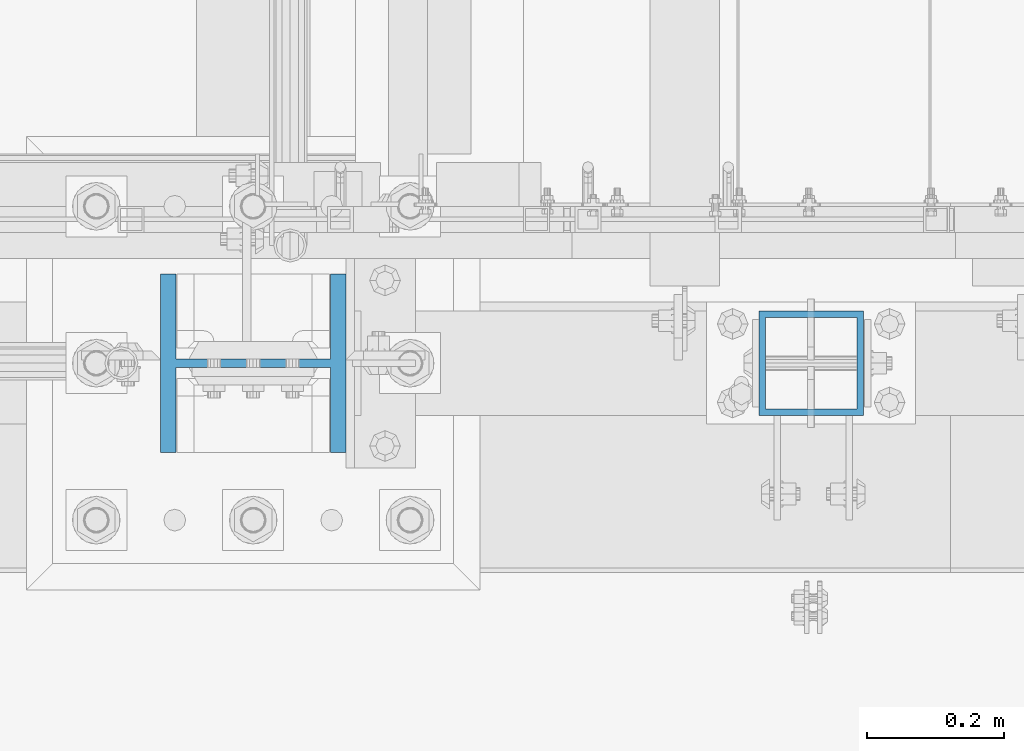
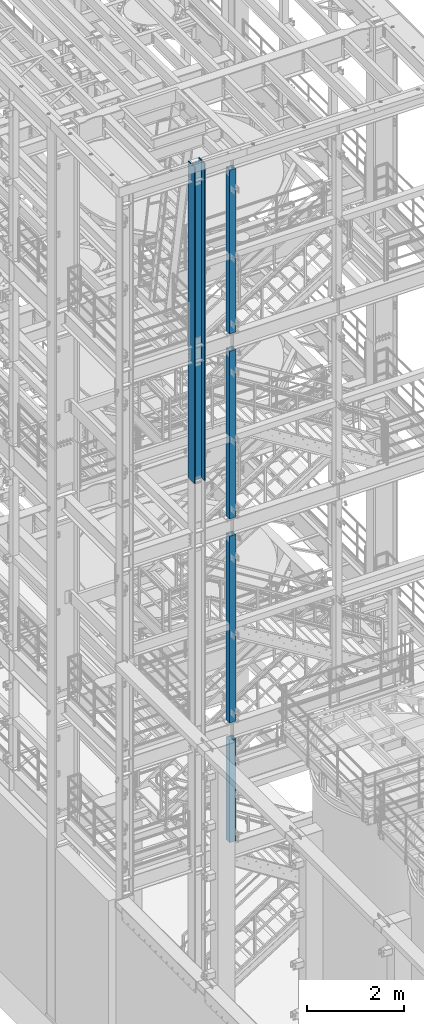
# One storey, part 568 of 1876: 5 columns, 5 elements without a shape of their own.
"""IFC2X3 building model written with IfcOpenShell, lengths in millimetres."""

from ifc_helpers import new_model, si_unit, frame, origin_with_axes, place, context, subcontext, project, spatial, faceted_brep, material, type_object, element, aggregate, save


model = new_model("IFC2X3")

# Units and contexts
model_context = context("Model", 3, precision=1e-05, world=origin_with_axes())
body_context = subcontext(model_context, "Body", "Model", "MODEL_VIEW")
ifc_project = project(units=[si_unit("LENGTHUNIT", "METRE", prefix="MILLI"), si_unit("AREAUNIT", "SQUARE_METRE"), si_unit("VOLUMEUNIT", "CUBIC_METRE"), si_unit("MASSUNIT", "GRAM", prefix="KILO"), si_unit("TIMEUNIT", "SECOND"), si_unit("PLANEANGLEUNIT", "RADIAN"), si_unit("SOLIDANGLEUNIT", "STERADIAN"), si_unit("THERMODYNAMICTEMPERATUREUNIT", "DEGREE_CELSIUS"), si_unit("LUMINOUSINTENSITYUNIT", "LUMEN")], contexts=[model_context])

# Site, building, storey
site_placement = place(None, origin_with_axes())
site = spatial("IfcSite", under=ifc_project, at=site_placement, CompositionType="ELEMENT")
building_placement = place(site_placement, origin_with_axes())
building = spatial("IfcBuilding", under=site, at=building_placement, Name="Undefined", CompositionType="ELEMENT")
storey_placement = place(building_placement, origin_with_axes())
storey = spatial("IfcBuildingStorey", under=building, at=storey_placement, Name="Undefined", CompositionType="ELEMENT", Elevation=0.0)

# Assembly, column
assembly_1_placement = place(storey_placement, origin_with_axes())
assembly_1 = element("IfcElementAssembly", 1, at=assembly_1_placement, inside=storey, Name="FRAME", AssemblyPlace="NOTDEFINED", PredefinedType="RIGID_FRAME")
ifc_material_1 = material()
column_type_1 = type_object("IfcColumnType", Name="HSS6X6X3/8", PredefinedType="NOTDEFINED")
column_1_placement = place(assembly_1_placement, frame((2540.0, -7112.0, 17983.2), z_axis=(-1.0, 0.0, 0.0), x_axis=(0.0, 0.0, 1.0)))
column_1 = element("IfcColumn", 2, at=column_1_placement, type_object=column_type_1, material=ifc_material_1, Name="COLUMN", ObjectType="HSS6X6X3/8", context=body_context, shape_type="Brep", body=[
    faceted_brep([(12.7000000000016, 66.6750000000002, -66.6750000000002), (12.7000000000016, -66.6750000000002, -66.6750000000002), (4149.72500000001, -66.6750000000002, -66.6750000000002), (4149.72500000001, 66.6750000000002, -66.6750000000002), (12.7000000000016, -66.6750000000002, 66.6750000000002), (4149.72500000001, -66.6750000000002, 66.6750000000002), (12.7000000000016, 66.6750000000002, 66.6750000000002), (4149.72500000001, 66.6750000000002, 66.6750000000002), (12.7000000000016, 76.1999999999998, -76.1999999999998), (12.7000000000016, 76.1999999999998, 76.1999999999998), (4149.72500000001, 76.1999999999998, 76.1999999999998), (4149.72500000001, 76.1999999999998, -76.1999999999998), (12.7000000000016, -76.1999999999998, 76.1999999999998), (4149.72500000001, -76.1999999999998, 76.1999999999998), (12.7000000000016, -76.1999999999998, -76.1999999999998), (4149.72500000001, -76.1999999999998, -76.1999999999998)], [[[0, 1, 2, 3]], [[1, 4, 5, 2]], [[4, 6, 7, 5]], [[6, 0, 3, 7]], [[8, 9, 10, 11]], [[9, 12, 13, 10]], [[12, 14, 15, 13]], [[14, 8, 11, 15]], [[13, 15, 11, 10], [5, 7, 3, 2]], [[14, 12, 9, 8], [6, 4, 1, 0]]]),
])
aggregate(assembly_1, [column_1])

assembly_2_placement = place(storey_placement, origin_with_axes())
assembly_2 = element("IfcElementAssembly", 3, at=assembly_2_placement, inside=storey, Name="FRAME", AssemblyPlace="NOTDEFINED", PredefinedType="RIGID_FRAME")
column_2_placement = place(assembly_2_placement, frame((2540.0, -7112.0, 13309.6), z_axis=(-1.0, 0.0, 0.0), x_axis=(0.0, 0.0, 1.0)))
column_2 = element("IfcColumn", 4, at=column_2_placement, type_object=column_type_1, material=ifc_material_1, Name="COLUMN", ObjectType="HSS6X6X3/8", context=body_context, shape_type="Brep", body=[
    faceted_brep([(12.7000000000016, 66.6750000000002, -66.6750000000002), (12.7000000000016, -66.6750000000002, -66.6750000000002), (4251.325, -66.6750000000002, -66.6750000000002), (4251.325, 66.6750000000002, -66.6750000000002), (12.7000000000016, -66.6750000000002, 66.6750000000002), (4251.325, -66.6750000000002, 66.6750000000002), (12.7000000000016, 66.6750000000002, 66.6750000000002), (4251.325, 66.6750000000002, 66.6750000000002), (12.7000000000016, 76.1999999999998, -76.1999999999998), (12.7000000000016, 76.1999999999998, 76.1999999999998), (4251.325, 76.1999999999998, 76.1999999999998), (4251.325, 76.1999999999998, -76.1999999999998), (12.7000000000016, -76.1999999999998, 76.1999999999998), (4251.325, -76.1999999999998, 76.1999999999998), (12.7000000000016, -76.1999999999998, -76.1999999999998), (4251.325, -76.1999999999998, -76.1999999999998)], [[[0, 1, 2, 3]], [[1, 4, 5, 2]], [[4, 6, 7, 5]], [[6, 0, 3, 7]], [[8, 9, 10, 11]], [[9, 12, 13, 10]], [[12, 14, 15, 13]], [[14, 8, 11, 15]], [[13, 15, 11, 10], [5, 7, 3, 2]], [[14, 12, 9, 8], [6, 4, 1, 0]]]),
])
aggregate(assembly_2, [column_2])

assembly_3_placement = place(storey_placement, origin_with_axes())
assembly_3 = element("IfcElementAssembly", 5, at=assembly_3_placement, inside=storey, Name="FRAME", AssemblyPlace="NOTDEFINED", PredefinedType="RIGID_FRAME")
column_3_placement = place(assembly_3_placement, frame((2540.0, -7112.0, 8153.4), z_axis=(-1.0, 0.0, 0.0), x_axis=(0.0, 0.0, 1.0)))
column_3 = element("IfcColumn", 6, at=column_3_placement, type_object=column_type_1, material=ifc_material_1, Name="COLUMN", ObjectType="HSS6X6X3/8", context=body_context, shape_type="Brep", body=[
    faceted_brep([(12.7000000000016, 66.6750000000002, -66.6750000000002), (12.7000000000016, -66.6750000000002, -66.6750000000002), (4733.925, -66.6750000000002, -66.6750000000002), (4733.925, 66.6750000000002, -66.6750000000002), (12.7000000000016, -66.6750000000002, 66.6750000000002), (4733.925, -66.6750000000002, 66.6750000000002), (12.7000000000016, 66.6750000000002, 66.6750000000002), (4733.925, 66.6750000000002, 66.6750000000002), (12.7000000000016, 76.1999999999998, -76.1999999999998), (12.7000000000016, 76.1999999999998, 76.1999999999998), (4733.925, 76.1999999999998, 76.1999999999998), (4733.925, 76.1999999999998, -76.1999999999998), (12.7000000000016, -76.1999999999998, 76.1999999999998), (4733.925, -76.1999999999998, 76.1999999999998), (12.7000000000016, -76.1999999999998, -76.1999999999998), (4733.925, -76.1999999999998, -76.1999999999998)], [[[0, 1, 2, 3]], [[1, 4, 5, 2]], [[4, 6, 7, 5]], [[6, 0, 3, 7]], [[8, 9, 10, 11]], [[9, 12, 13, 10]], [[12, 14, 15, 13]], [[14, 8, 11, 15]], [[13, 15, 11, 10], [5, 7, 3, 2]], [[14, 12, 9, 8], [6, 4, 1, 0]]]),
])
aggregate(assembly_3, [column_3])

assembly_4_placement = place(storey_placement, origin_with_axes())
assembly_4 = element("IfcElementAssembly", 7, at=assembly_4_placement, inside=storey, Name="FRAME", AssemblyPlace="NOTDEFINED", PredefinedType="RIGID_FRAME")
column_4_placement = place(assembly_4_placement, frame((2540.0, -7112.0, 5130.8), z_axis=(-1.0, 0.0, 0.0), x_axis=(0.0, 0.0, 1.0)))
column_4 = element("IfcColumn", 8, at=column_4_placement, type_object=column_type_1, material=ifc_material_1, Name="COLUMN", ObjectType="HSS6X6X3/8", context=body_context, shape_type="Brep", body=[
    faceted_brep([(12.7000000000016, 66.6750000000002, -66.6750000000002), (12.7000000000016, -66.6750000000002, -66.6750000000002), (2600.325, -66.6750000000002, -66.6750000000002), (2600.325, 66.6750000000002, -66.6750000000002), (12.7000000000016, -66.6750000000002, 66.6750000000002), (2600.325, -66.6750000000002, 66.6750000000002), (12.7000000000016, 66.6750000000002, 66.6750000000002), (2600.325, 66.6750000000002, 66.6750000000002), (12.7000000000016, 76.1999999999998, -76.1999999999998), (12.7000000000016, 76.1999999999998, 76.1999999999998), (2600.325, 76.1999999999998, 76.1999999999998), (2600.325, 76.1999999999998, -76.1999999999998), (12.7000000000016, -76.1999999999998, 76.1999999999998), (2600.325, -76.1999999999998, 76.1999999999998), (12.7000000000016, -76.1999999999998, -76.1999999999998), (2600.325, -76.1999999999998, -76.1999999999998)], [[[0, 1, 2, 3]], [[1, 4, 5, 2]], [[4, 6, 7, 5]], [[6, 0, 3, 7]], [[8, 9, 10, 11]], [[9, 12, 13, 10]], [[12, 14, 15, 13]], [[14, 8, 11, 15]], [[13, 15, 11, 10], [5, 7, 3, 2]], [[14, 12, 9, 8], [6, 4, 1, 0]]]),
])
aggregate(assembly_4, [column_4])

assembly_5_placement = place(storey_placement, origin_with_axes())
assembly_5 = element("IfcElementAssembly", 9, at=assembly_5_placement, inside=storey, Name="COLUMN", AssemblyPlace="NOTDEFINED", PredefinedType="RIGID_FRAME")
ifc_material_2 = material(Name="STEEL/A992")
column_type_2 = type_object("IfcColumnType", Name="W10X77", PredefinedType="NOTDEFINED")
column_5_placement = place(assembly_5_placement, frame((1727.2, -7112.0, 14528.8), z_axis=(-1.0, 0.0, 0.0), x_axis=(0.0, 0.0, 1.0)))
column_5 = element("IfcColumn", 10, at=column_5_placement, type_object=column_type_2, material=ifc_material_2, Name="COLUMN", ObjectType="W10X77", context=body_context, shape_type="Brep", body=[
    faceted_brep([(15.8749999999945, 6.35000000000036, 82.471111788822), (15.8749999999945, 6.35000000000036, -82.471111788822), (6.35000000000036, -3.17500029428084, -80.9625), (6.35000000000036, -3.17500029428084, 80.9625), (8026.39999999999, 130.175, -134.9375), (8026.39999999999, -130.175, -134.9375), (25.4000000342548, -130.175, -134.9375), (25.4000000342548, 130.175, -134.9375), (8026.39999999999, -130.175, -112.7125), (38.1000000342628, -130.175, -112.7125), (6.35000000000036, -130.175, -112.7125), (6.35000000000036, -130.175, -115.887499965744), (38.1000000342628, -6.35000000000036, -112.7125), (6.35000000000036, -6.35000000000036, -112.7125), (8026.39999999999, -6.35000000000036, -112.7125), (6.35000000000036, -130.175, 112.7125), (38.1000000342628, -130.175, 112.7125), (8026.39999999999, -130.175, 112.7125), (8026.39999999999, -130.175, 134.9375), (25.4000000342548, -130.175, 134.9375), (6.35000000000036, -130.175, 115.887499965744), (8026.39999999999, 130.175, 134.9375), (25.4000000342548, 130.175, 134.9375), (6.35000000000036, 130.175, 115.887499965744), (8026.39999999999, 130.175, 112.7125), (38.1000000342628, 130.175, 112.7125), (6.35000000000036, 130.175, 112.7125), (6.35000000000036, -6.35000000000036, 112.7125), (6.35000000000036, 6.35000000000036, 112.7125), (6.35000000000036, -3.17500029428084, 112.7125), (38.1000000342628, -6.35000000000036, 112.7125), (8026.39999999999, -6.35000000000036, 112.7125), (36.5460444266337, -6.35000000000036, 102.901210428595), (32.0362896056668, -6.35000000000036, 94.050318239714), (25.0121817945492, -6.35000000000036, 87.0262104285954), (16.1612896056668, -6.35000000000036, 82.5164556076289), (6.35000000000036, -6.35000000000036, 80.9625), (6.35000000000036, -6.35000000000036, -80.9625), (16.1612896056668, -6.35000000000036, -82.5164556076289), (25.0121817945492, -6.35000000000036, -87.0262104285954), (32.0362896056668, -6.35000000000036, -94.050318239714), (36.5460444266337, -6.35000000000036, -102.901210428595), (16.1612896056668, 6.35000000000036, -82.5164556076289), (25.0121817945492, 6.35000000000036, -87.0262104285954), (32.0362896056668, 6.35000000000036, -94.050318239714), (36.5460444266337, 6.35000000000036, -102.901210428595), (38.1000000342628, 6.35000000000036, -112.7125), (38.1000000342628, 130.175, -112.7125), (6.35000000000036, 130.175, -112.7125), (6.35000000000036, 6.35000000000036, -112.7125), (15.8749999999945, 6.35000000000036, -112.7125), (8026.39999999999, 6.35000000000036, -112.7125), (8026.39999999999, 130.175, -112.7125), (6.35000000000036, -3.17500029428084, -112.7125), (6.35000000000036, 130.175, -115.887499965744), (8026.39999999999, 6.35000000000036, 112.7125), (38.1000000342628, 6.35000000000036, 112.7125), (15.8749999999945, 6.35000000000036, 112.7125), (36.5460444266337, 6.35000000000036, 102.901210428595), (32.0362896056668, 6.35000000000036, 94.050318239714), (25.0121817945492, 6.35000000000036, 87.0262104285954), (16.1612896056668, 6.35000000000036, 82.5164556076289)], [[[0, 1, 2, 3]], [[4, 5, 6, 7]], [[5, 8, 9, 10, 11, 6]], [[12, 13, 10, 9, 8, 14]], [[15, 16, 17, 18, 19, 20]], [[18, 21, 22, 19]], [[19, 22, 23, 20]], [[21, 24, 25, 26, 23, 22]], [[27, 15, 20, 23, 26, 28, 29]], [[16, 15, 27, 30, 31, 17]], [[14, 31, 30, 32, 33, 34, 35, 36, 37, 38, 39, 40, 41, 12]], [[38, 42, 43, 39]], [[39, 43, 44, 40]], [[40, 44, 45, 41]], [[41, 45, 46, 12]], [[47, 48, 49, 50, 46, 51, 52]], [[12, 46, 50, 49, 53, 13]], [[49, 48, 54, 11, 10, 13, 53]], [[6, 11, 54, 7]], [[48, 47, 52, 4, 7, 54]], [[51, 55, 24, 21, 18, 17, 31, 14, 8, 5, 4, 52]], [[56, 57, 28, 26, 25, 24, 55]], [[27, 29, 28, 57, 56, 30]], [[30, 56, 58, 32]], [[32, 58, 59, 33]], [[33, 59, 60, 34]], [[34, 60, 61, 35]], [[36, 35, 61, 0, 3]], [[37, 36, 3, 2]], [[42, 38, 37, 2, 1]], [[61, 60, 59, 58, 56, 55, 51, 46, 45, 44, 43, 42, 1, 0]]]),
])
aggregate(assembly_5, [column_5])

save(model, "model.ifc")
